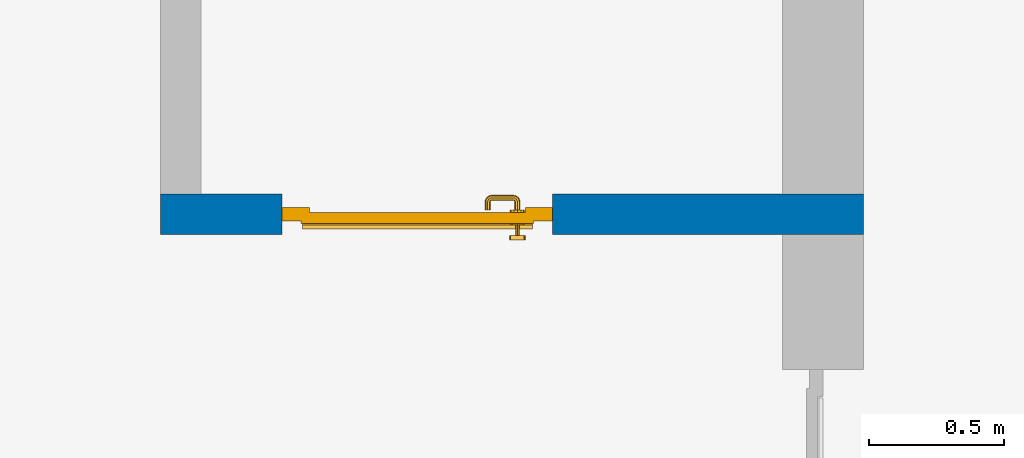
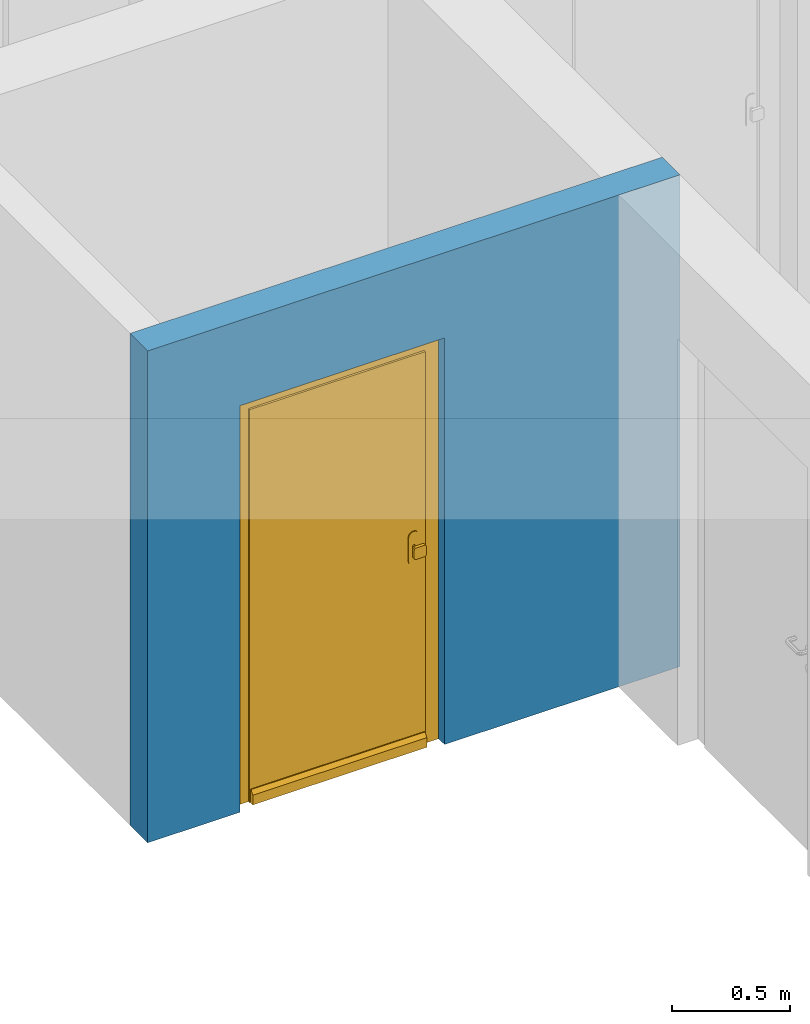
# One storey, part 9 of 48: 1 door, 1 wall, 1 opening.
"""IFC4 building model written with IfcOpenShell, lengths in metres."""

from ifc_helpers import new_model, entity, si_unit, converted_unit, derived_unit, direction, frame, origin_with_axes, place, context, subcontext, project, spatial, polygons, source, transform, mapped, material, type_object, element, fill, save


model = new_model("IFC4")

# Units and contexts
model_context = context("Model", 3, precision=1e-05, world=origin_with_axes(), true_north=direction((0.0, 1.0)))
body_context = subcontext(model_context, "Body", "Model", "MODEL_VIEW")
ifc_project = project(units=[si_unit("LENGTHUNIT", "METRE"), si_unit("AREAUNIT", "SQUARE_METRE"), si_unit("VOLUMEUNIT", "CUBIC_METRE"), converted_unit("PLANEANGLEUNIT", "DEGREE", entity("IfcPlaneAngleMeasure", 0.0174532925199), si_unit("PLANEANGLEUNIT", "RADIAN"), dimensions=[0, 0, 0, 0, 0, 0, 0]), converted_unit("TIMEUNIT", "Year", entity("IfcTimeMeasure", 31556926.0), si_unit("TIMEUNIT", "SECOND"), dimensions=[0, 0, 1, 0, 0, 0, 0]), si_unit("MASSUNIT", "GRAM", prefix="KILO"), si_unit("THERMODYNAMICTEMPERATUREUNIT", "DEGREE_CELSIUS"), si_unit("LUMINOUSINTENSITYUNIT", "LUMEN"), si_unit("ENERGYUNIT", "JOULE", prefix="MEGA"), derived_unit("THERMALCONDUCTANCEUNIT", [(si_unit("POWERUNIT", "WATT"), 1), (si_unit("LENGTHUNIT", "METRE"), -1), (si_unit("THERMODYNAMICTEMPERATUREUNIT", "KELVIN"), -1)]), derived_unit("SPECIFICHEATCAPACITYUNIT", [(si_unit("ENERGYUNIT", "JOULE"), 1), (si_unit("MASSUNIT", "GRAM", prefix="KILO"), -1), (si_unit("THERMODYNAMICTEMPERATUREUNIT", "KELVIN"), -1)]), derived_unit("MASSDENSITYUNIT", [(si_unit("MASSUNIT", "GRAM", prefix="KILO"), 1), (si_unit("VOLUMEUNIT", "CUBIC_METRE"), -1)])], contexts=[model_context])

# Site, building, storey
site_placement = place(None, origin_with_axes())
site = spatial("IfcSite", under=ifc_project, at=site_placement, CompositionType="ELEMENT")
building_placement = place(site_placement, origin_with_axes())
building = spatial("IfcBuilding", under=site, at=building_placement, CompositionType="ELEMENT")
storey_placement = place(building_placement, frame((0.0, 0.0, 3.4), z_axis=(0.0, 0.0, 1.0), x_axis=(1.0, 0.0, 0.0)))
storey = spatial("IfcBuildingStorey", under=building, at=storey_placement, Name="1. Geschoss", CompositionType="ELEMENT", Elevation=3.4)

# Wall, opening, door
ifc_material = material()
wall_type = type_object("IfcWallType", Name="150", PredefinedType="NOTDEFINED")
wall_placement = place(storey_placement, frame((-4.9421993804, -0.428812231043, 0.0), z_axis=(0.0, 0.0, 1.0), x_axis=(-1.0, 0.0, 0.0)))
wall = element("IfcWall", 1, at=wall_placement, inside=storey, type_object=wall_type, material=ifc_material, Name="Wand-002", PredefinedType="NOTDEFINED", context=body_context, shape_type="Tessellation", body=[
    polygons([(2.15, 0.0, 2.1), (2.15, 0.0, 0.0), (2.6, 0.0, 0.0), (2.6, 0.0, 2.54), (0.0, 0.0, 2.54), (0.0, 0.0, 0.0), (1.15, 0.0, 0.0), (1.15, 0.0, 2.1), (2.15, 0.1, 2.1), (2.15, 0.1, 0.0), (2.15, 0.15, 0.0), (2.6, 0.15, 0.0), (2.6, 0.15, 2.54), (0.0, 0.15, 2.54), (0.0, 0.15, 0.0), (1.15, 0.1, 0.0), (1.15, 0.15, 0.0), (1.15, 0.1, 2.1), (2.15, 0.15, 2.1), (1.15, 0.15, 2.1)], [[[1, 2, 3, 4, 5, 6, 7, 8]], [[2, 1, 9, 10]], [[2, 10, 11, 12, 3]], [[4, 3, 12, 13]], [[5, 4, 13, 14]], [[14, 15, 6, 5]], [[16, 7, 6, 15, 17]], [[8, 7, 16, 18]], [[1, 8, 18, 9]], [[10, 9, 19, 11]], [[12, 11, 19, 20, 17, 15, 14, 13]], [[18, 16, 17, 20]], [[9, 18, 20, 19]]], closed=True),
])
opening_placement = place(wall_placement, frame((1.65, 0.0, 0.0), z_axis=(0.0, 0.0, 1.0), x_axis=(1.0, 0.0, 0.0)))
opening = element("IfcOpeningElement", 2, at=opening_placement, cuts=wall, context=body_context, identifier="Reference", shape_type="Tessellation", body=[
    polygons([(-0.5, 0.1, 0.0), (-0.5, 0.1, 2.1), (-0.5, 0.151, 2.1), (-0.5, 0.151, 0.0), (-0.5, -0.001, 0.0), (-0.5, -0.001, 2.1), (0.5, 0.1, 2.1), (0.5, 0.151, 2.1), (0.5, -0.001, 2.1), (0.5, 0.151, 0.0), (0.5, 0.1, 0.0), (0.5, -0.001, 0.0)], [[[1, 2, 3, 4]], [[2, 1, 5, 6]], [[7, 8, 3, 2, 6, 9]], [[8, 10, 4, 3]], [[1, 4, 10, 11, 12, 5]], [[6, 5, 12, 9]], [[7, 11, 10, 8]], [[11, 7, 9, 12]]], closed=True),
])
door_type = type_object("IfcDoorType", Name="Eingang 01 1-Fl 26", OperationType="SINGLE_SWING_RIGHT", PredefinedType="DOOR")
shared_shape = source(origin_with_axes(), body_context, "Body", "Tessellation", [
    polygons([(0.5, -0.05, 0.0), (0.5, -0.03, 0.0), (0.5, -0.03, 2.1), (0.5, -0.05, 2.1), (0.4, -0.05, 0.0), (0.4, -0.03, 0.0), (0.4, -0.03, 2.0), (0.1301, -0.03, 2.0), (0.0001, -0.03, 2.0), (-0.4, -0.03, 2.0), (-0.4, -0.03, 0.0), (-0.5, -0.03, 0.0), (-0.5, -0.03, 2.1), (-0.5, -0.05, 2.1), (-0.5, -0.05, 0.0), (-0.4, -0.05, 0.0), (-0.4, -0.05, 2.0), (0.0001, -0.05, 2.0), (0.1301, -0.05, 2.0), (0.4, -0.05, 2.0)], [[[1, 2, 3, 4]], [[5, 6, 2, 1]], [[2, 6, 7, 8, 9, 10, 11, 12, 13, 3]], [[4, 3, 13, 14]], [[1, 4, 14, 15, 16, 17, 18, 19, 20, 5]], [[20, 7, 6, 5]], [[19, 8, 7, 20]], [[18, 9, 8, 19]], [[17, 10, 9, 18]], [[16, 11, 10, 17]], [[15, 12, 11, 16]], [[14, 13, 12, 15]]], closed=True),
    polygons([(0.5, -0.03, 0.0), (0.5, 0.0, 0.0), (0.5, 0.0, 2.1), (0.5, -0.03, 2.1), (0.43, -0.03, 0.0), (0.43, 0.0, 0.0), (0.43, 0.0, 2.03), (0.1001, 0.0, 2.03), (0.0301, 0.0, 2.03), (-0.43, 0.0, 2.03), (-0.43, 0.0, 0.0), (-0.5, 0.0, 0.0), (-0.5, 0.0, 2.1), (-0.5, -0.03, 2.1), (-0.5, -0.03, 0.0), (-0.43, -0.03, 0.0), (-0.43, -0.03, 2.03), (0.0301, -0.03, 2.03), (0.1001, -0.03, 2.03), (0.43, -0.03, 2.03)], [[[1, 2, 3, 4]], [[5, 6, 2, 1]], [[2, 6, 7, 8, 9, 10, 11, 12, 13, 3]], [[4, 3, 13, 14]], [[1, 4, 14, 15, 16, 17, 18, 19, 20, 5]], [[20, 7, 6, 5]], [[19, 8, 7, 20]], [[18, 9, 8, 19]], [[17, 10, 9, 18]], [[16, 11, 10, 17]], [[15, 12, 11, 16]], [[14, 13, 12, 15]]], closed=True),
    polygons([(0.43, 0.01, 0.0), (-0.43, 0.01, 0.0), (-0.43, 0.01, 2.03), (0.43, 0.01, 2.03), (0.43, -0.03, 0.0), (-0.43, -0.03, 0.0), (-0.43, -0.03, 2.03), (0.43, -0.03, 2.03)], [[[1, 2, 3, 4]], [[2, 1, 5, 6]], [[3, 2, 6, 7]], [[4, 3, 7, 8]], [[1, 4, 8, 5]], [[6, 5, 8, 7]]], closed=True),
    polygons([(0.425, 0.03, 0.0), (-0.425, 0.03, 0.0), (-0.425, 0.03, 0.05), (0.425, 0.03, 0.05), (0.425, 0.01, 0.0), (-0.425, 0.01, 0.0), (-0.425, 0.01, 0.07), (-0.425, 0.015, 0.07), (0.425, 0.015, 0.07), (0.425, 0.01, 0.07)], [[[1, 2, 3, 4]], [[5, 6, 2, 1]], [[2, 6, 7, 8, 3]], [[4, 3, 8, 9]], [[1, 4, 9, 10, 5]], [[10, 7, 6, 5]], [[9, 8, 7, 10]]], closed=True),
    polygons([(-0.3835, -0.04, 1.0733826859), (-0.37, -0.04, 1.077), (-0.37, -0.0399, 1.077), (-0.3835, -0.0399, 1.0733826859), (-0.393382685902, -0.04, 1.0635), (-0.397, -0.04, 1.05), (-0.393382685902, -0.04, 1.0365), (-0.3835, -0.04, 1.0266173141), (-0.37, -0.04, 1.023), (-0.3565, -0.04, 1.0266173141), (-0.346617314098, -0.04, 1.0365), (-0.343, -0.04, 1.05), (-0.346617314098, -0.04, 1.0635), (-0.3565, -0.04, 1.0733826859), (-0.3565, -0.0399, 1.0733826859), (-0.37, -0.0301, 1.077), (-0.3835, -0.0301, 1.0733826859), (-0.393382685902, -0.0399, 1.0635), (-0.397, -0.0399, 1.05), (-0.393382685902, -0.0399, 1.0365), (-0.3835, -0.0399, 1.0266173141), (-0.37, -0.0399, 1.023), (-0.3565, -0.0399, 1.0266173141), (-0.346617314098, -0.0399, 1.0365), (-0.343, -0.0399, 1.05), (-0.346617314098, -0.0399, 1.0635), (-0.3565, -0.0301, 1.0733826859), (-0.37, -0.03, 1.077), (-0.3835, -0.03, 1.0733826859), (-0.393382685902, -0.0301, 1.0635), (-0.397, -0.0301, 1.05), (-0.393382685902, -0.0301, 1.0365), (-0.3835, -0.0301, 1.0266173141), (-0.37, -0.0301, 1.023), (-0.3565, -0.0301, 1.0266173141), (-0.346617314098, -0.0301, 1.0365), (-0.343, -0.0301, 1.05), (-0.346617314098, -0.0301, 1.0635), (-0.3565, -0.03, 1.0733826859), (-0.346617314098, -0.03, 1.0635), (-0.343, -0.03, 1.05), (-0.346617314098, -0.03, 1.0365), (-0.3565, -0.03, 1.0266173141), (-0.37, -0.03, 1.023), (-0.3835, -0.03, 1.0266173141), (-0.393382685902, -0.03, 1.0365), (-0.397, -0.03, 1.05), (-0.393382685902, -0.03, 1.0635)], [[[1, 2, 3, 4]], [[2, 1, 5, 6, 7, 8, 9, 10, 11, 12, 13, 14]], [[2, 14, 15, 3]], [[4, 3, 16, 17]], [[5, 1, 4, 18]], [[6, 5, 18, 19]], [[7, 6, 19, 20]], [[8, 7, 20, 21]], [[9, 8, 21, 22]], [[10, 9, 22, 23]], [[11, 10, 23, 24]], [[12, 11, 24, 25]], [[13, 12, 25, 26]], [[14, 13, 26, 15]], [[3, 15, 27, 16]], [[17, 16, 28, 29]], [[18, 4, 17, 30]], [[19, 18, 30, 31]], [[20, 19, 31, 32]], [[21, 20, 32, 33]], [[22, 21, 33, 34]], [[23, 22, 34, 35]], [[24, 23, 35, 36]], [[25, 24, 36, 37]], [[26, 25, 37, 38]], [[15, 26, 38, 27]], [[16, 27, 39, 28]], [[28, 39, 40, 41, 42, 43, 44, 45, 46, 47, 48, 29]], [[30, 17, 29, 48]], [[31, 30, 48, 47]], [[32, 31, 47, 46]], [[33, 32, 46, 45]], [[34, 33, 45, 44]], [[35, 34, 44, 43]], [[36, 35, 43, 42]], [[37, 36, 42, 41]], [[38, 37, 41, 40]], [[27, 38, 40, 39]]], closed=True),
    polygons([(-0.362532169224, -0.04, 0.959692280177), (-0.365, -0.04, 0.9544), (-0.365, -0.04, 0.952886751346), (-0.346703916638, -0.04, 0.96345), (-0.35655, -0.04, 0.973296083362), (-0.363279754556, -0.04, 0.961639806549), (-0.362532169224, -0.039, 0.959692280177), (-0.365, -0.039, 0.9544), (-0.365, -0.039, 0.952886751346), (-0.365, -0.039, 0.95), (-0.365, -0.039, 0.947113248654), (-0.365, -0.039, 0.941339745962), (-0.365, -0.039, 0.9375), (-0.365, -0.04, 0.9375), (-0.365, -0.04, 0.941339745962), (-0.365, -0.04, 0.947113248654), (-0.365, -0.04, 0.95), (-0.3431, -0.04, 0.95), (-0.346617314098, -0.04, 0.9635), (-0.3565, -0.04, 0.973382685902), (-0.364624817685, -0.04, 0.965143815798), (-0.37, -0.04, 0.9769), (-0.37, -0.04, 0.967425445323), (-0.364624817685, -0.039, 0.965143815798), (-0.363279754556, -0.039, 0.961639806549), (-0.35705, -0.039, 0.972430057958), (-0.347569942042, -0.039, 0.96295), (-0.3441, -0.039, 0.95), (-0.347569942042, -0.039, 0.93705), (-0.35705, -0.039, 0.927569942042), (-0.37, -0.039, 0.9241), (-0.37, -0.039, 0.9325), (-0.366464466094, -0.039, 0.933964466094), (-0.366464466094, -0.04, 0.933964466094), (-0.35655, -0.04, 0.926703916638), (-0.37, -0.04, 0.9325), (-0.37, -0.04, 0.9231), (-0.346703916638, -0.04, 0.93655), (-0.343, -0.04, 0.95), (-0.346617314098, -0.0399, 0.9635), (-0.3565, -0.0399, 0.973382685902), (-0.37, -0.04, 0.977), (-0.375375182315, -0.04, 0.965143815798), (-0.38345, -0.04, 0.973296083362), (-0.376720245444, -0.04, 0.961639806549), (-0.37, -0.039, 0.967425445323), (-0.37, -0.039, 0.9759), (-0.357, -0.039, 0.972516660498), (-0.347483339502, -0.039, 0.963), (-0.344, -0.039, 0.95), (-0.347483339502, -0.039, 0.937), (-0.357, -0.039, 0.927483339502), (-0.38295, -0.039, 0.927569942042), (-0.375, -0.039, 0.941339745962), (-0.375, -0.039, 0.9375), (-0.373535533906, -0.039, 0.933964466094), (-0.37, -0.039, 0.924), (-0.373535533906, -0.04, 0.933964466094), (-0.375, -0.04, 0.9375), (-0.375, -0.04, 0.941339745962), (-0.38345, -0.04, 0.926703916638), (-0.37, -0.04, 0.923), (-0.3565, -0.04, 0.926617314098), (-0.346617314098, -0.04, 0.9365), (-0.343, -0.0399, 0.95), (-0.346617314098, -0.0301, 0.9635), (-0.3565, -0.0301, 0.973382685902), (-0.37, -0.0399, 0.977), (-0.3835, -0.04, 0.973382685902), (-0.375375182315, -0.039, 0.965143815798), (-0.377467830776, -0.04, 0.959692280177), (-0.393296083362, -0.04, 0.96345), (-0.375, -0.04, 0.952886751346), (-0.375, -0.04, 0.9544), (-0.377467830776, -0.039, 0.959692280177), (-0.376720245444, -0.039, 0.961639806549), (-0.38295, -0.039, 0.972430057958), (-0.37, -0.039, 0.976), (-0.357, -0.0389, 0.972516660498), (-0.347483339502, -0.0389, 0.963), (-0.344, -0.0389, 0.95), (-0.347483339502, -0.0389, 0.937), (-0.357, -0.0389, 0.927483339502), (-0.392430057958, -0.039, 0.93705), (-0.375, -0.039, 0.947113248654), (-0.375, -0.039, 0.9544), (-0.375, -0.04, 0.95), (-0.375, -0.04, 0.947113248654), (-0.375, -0.039, 0.95), (-0.375, -0.039, 0.952886751346), (-0.383, -0.039, 0.927483339502), (-0.37, -0.0389, 0.924), (-0.393296083362, -0.04, 0.93655), (-0.3835, -0.04, 0.926617314098), (-0.37, -0.0399, 0.923), (-0.3565, -0.0399, 0.926617314098), (-0.346617314098, -0.0399, 0.9365), (-0.343, -0.0301, 0.95), (-0.346617314098, -0.03, 0.9635), (-0.3565, -0.03, 0.973382685902), (-0.37, -0.0301, 0.977), (-0.3835, -0.0399, 0.973382685902), (-0.393382685902, -0.04, 0.9635), (-0.3969, -0.04, 0.95), (-0.392430057958, -0.039, 0.96295), (-0.383, -0.039, 0.972516660498), (-0.37, -0.0389, 0.976), (-0.357, -0.0301, 0.972516660498), (-0.347483339502, -0.0301, 0.963), (-0.344, -0.0301, 0.95), (-0.347483339502, -0.0301, 0.937), (-0.357, -0.0301, 0.927483339502), (-0.392516660498, -0.039, 0.937), (-0.3959, -0.039, 0.95), (-0.383, -0.0389, 0.927483339502), (-0.37, -0.0301, 0.924), (-0.393382685902, -0.04, 0.9365), (-0.3835, -0.0399, 0.926617314098), (-0.37, -0.0301, 0.923), (-0.3565, -0.0301, 0.926617314098), (-0.346617314098, -0.0301, 0.9365), (-0.343, -0.03, 0.95), (-0.346703916638, -0.03, 0.96345), (-0.35655, -0.03, 0.973296083362), (-0.37, -0.03, 0.977), (-0.3835, -0.0301, 0.973382685902), (-0.393382685902, -0.0399, 0.9635), (-0.397, -0.04, 0.95), (-0.392516660498, -0.039, 0.963), (-0.383, -0.0389, 0.972516660498), (-0.37, -0.0301, 0.976), (-0.357, -0.03, 0.972516660498), (-0.347483339502, -0.03, 0.963), (-0.344, -0.03, 0.95), (-0.347483339502, -0.03, 0.937), (-0.357, -0.03, 0.927483339502), (-0.392516660498, -0.0389, 0.937), (-0.396, -0.039, 0.95), (-0.383, -0.0301, 0.927483339502), (-0.37, -0.03, 0.924), (-0.393382685902, -0.0399, 0.9365), (-0.3835, -0.0301, 0.926617314098), (-0.37, -0.03, 0.923), (-0.3565, -0.03, 0.926617314098), (-0.346617314098, -0.03, 0.9365), (-0.3431, -0.03, 0.95), (-0.347396736961, -0.03, 0.96305), (-0.35695, -0.03, 0.972603263039), (-0.37, -0.03, 0.9769), (-0.3835, -0.03, 0.973382685902), (-0.393382685902, -0.0301, 0.9635), (-0.397, -0.0399, 0.95), (-0.392516660498, -0.0389, 0.963), (-0.383, -0.0301, 0.972516660498), (-0.37, -0.03, 0.976), (-0.3439, -0.03, 0.95), (-0.347396736961, -0.03, 0.93695), (-0.35695, -0.03, 0.927396736961), (-0.392516660498, -0.0301, 0.937), (-0.396, -0.0389, 0.95), (-0.383, -0.03, 0.927483339502), (-0.37, -0.03, 0.9239), (-0.393382685902, -0.0301, 0.9365), (-0.3835, -0.03, 0.926617314098), (-0.37, -0.03, 0.9231), (-0.35655, -0.03, 0.926703916638), (-0.346703916638, -0.03, 0.93655), (-0.37, -0.03, 0.9761), (-0.38345, -0.03, 0.973296083362), (-0.393382685902, -0.03, 0.9635), (-0.397, -0.0301, 0.95), (-0.392516660498, -0.0301, 0.963), (-0.383, -0.03, 0.972516660498), (-0.392516660498, -0.03, 0.937), (-0.396, -0.0301, 0.95), (-0.38305, -0.03, 0.927396736961), (-0.393382685902, -0.03, 0.9365), (-0.38345, -0.03, 0.926703916638), (-0.38305, -0.03, 0.972603263039), (-0.393296083362, -0.03, 0.96345), (-0.397, -0.03, 0.95), (-0.392516660498, -0.03, 0.963), (-0.392603263039, -0.03, 0.93695), (-0.396, -0.03, 0.95), (-0.393296083362, -0.03, 0.93655), (-0.392603263039, -0.03, 0.96305), (-0.3969, -0.03, 0.95), (-0.3961, -0.03, 0.95)], [[[1, 2, 3, 4, 5, 6]], [[2, 1, 7, 8]], [[2, 8, 9, 10, 11, 12, 13, 14, 15, 16, 17, 3]], [[17, 18, 4, 3]], [[19, 20, 5, 4]], [[21, 6, 5, 22, 23]], [[1, 6, 21, 24, 25, 7]], [[7, 25, 26, 27, 9, 8]], [[9, 27, 28, 10]], [[10, 28, 29, 11]], [[11, 29, 30, 12]], [[31, 32, 33, 13, 12, 30]], [[14, 13, 33, 34]], [[35, 15, 14, 34, 36, 37]], [[15, 35, 38, 16]], [[16, 38, 18, 17]], [[39, 19, 4, 18]], [[40, 41, 20, 19]], [[20, 42, 22, 5]], [[43, 23, 22, 44, 45]], [[21, 23, 46, 24]], [[24, 46, 47, 26, 25]], [[27, 26, 48, 49]], [[28, 27, 49, 50]], [[29, 28, 50, 51]], [[30, 29, 51, 52]], [[53, 54, 55, 56, 32, 31]], [[34, 33, 32, 36]], [[31, 30, 52, 57]], [[37, 36, 58, 59, 60, 61]], [[62, 63, 35, 37]], [[63, 64, 38, 35]], [[64, 39, 18, 38]], [[65, 40, 19, 39]], [[66, 67, 41, 40]], [[41, 68, 42, 20]], [[42, 69, 44, 22]], [[23, 43, 70, 46]], [[71, 45, 44, 72, 73, 74]], [[43, 45, 71, 75, 76, 70]], [[70, 76, 77, 47, 46]], [[26, 47, 78, 48]], [[49, 48, 79, 80]], [[50, 49, 80, 81]], [[51, 50, 81, 82]], [[52, 51, 82, 83]], [[54, 53, 84, 85]], [[86, 74, 73, 87, 88, 60, 59, 55, 54, 85, 89, 90]], [[58, 56, 55, 59]], [[36, 32, 56, 58]], [[53, 31, 57, 91]], [[57, 52, 83, 92]], [[88, 93, 61, 60]], [[94, 62, 37, 61]], [[95, 96, 63, 62]], [[96, 97, 64, 63]], [[97, 65, 39, 64]], [[98, 66, 40, 65]], [[99, 100, 67, 66]], [[67, 101, 68, 41]], [[68, 102, 69, 42]], [[69, 103, 72, 44]], [[73, 72, 104, 87]], [[71, 74, 86, 75]], [[75, 86, 90, 105, 77, 76]], [[47, 77, 106, 78]], [[48, 78, 107, 79]], [[80, 79, 108, 109]], [[81, 80, 109, 110]], [[82, 81, 110, 111]], [[83, 82, 111, 112]], [[84, 53, 91, 113]], [[85, 84, 114, 89]], [[87, 104, 93, 88]], [[89, 114, 105, 90]], [[91, 57, 92, 115]], [[92, 83, 112, 116]], [[117, 94, 61, 93]], [[118, 95, 62, 94]], [[119, 120, 96, 95]], [[120, 121, 97, 96]], [[121, 98, 65, 97]], [[122, 99, 66, 98]], [[123, 124, 100, 99]], [[100, 125, 101, 67]], [[101, 126, 102, 68]], [[102, 127, 103, 69]], [[103, 128, 104, 72]], [[77, 105, 129, 106]], [[78, 106, 130, 107]], [[79, 107, 131, 108]], [[109, 108, 132, 133]], [[110, 109, 133, 134]], [[111, 110, 134, 135]], [[112, 111, 135, 136]], [[113, 91, 115, 137]], [[114, 84, 113, 138]], [[128, 117, 93, 104]], [[105, 114, 138, 129]], [[115, 92, 116, 139]], [[116, 112, 136, 140]], [[141, 118, 94, 117]], [[142, 119, 95, 118]], [[143, 144, 120, 119]], [[144, 145, 121, 120]], [[145, 122, 98, 121]], [[146, 123, 99, 122]], [[147, 148, 124, 123]], [[124, 149, 125, 100]], [[125, 150, 126, 101]], [[126, 151, 127, 102]], [[127, 152, 128, 103]], [[106, 129, 153, 130]], [[107, 130, 154, 131]], [[108, 131, 155, 132]], [[133, 132, 148, 147]], [[134, 133, 147, 156]], [[135, 134, 156, 157]], [[136, 135, 157, 158]], [[137, 115, 139, 159]], [[138, 113, 137, 160]], [[152, 141, 117, 128]], [[129, 138, 160, 153]], [[139, 116, 140, 161]], [[140, 136, 158, 162]], [[163, 142, 118, 141]], [[164, 143, 119, 142]], [[165, 166, 144, 143]], [[166, 167, 145, 144]], [[167, 146, 122, 145]], [[156, 147, 123, 146]], [[148, 168, 149, 124]], [[149, 169, 150, 125]], [[150, 170, 151, 126]], [[151, 171, 152, 127]], [[130, 153, 172, 154]], [[131, 154, 173, 155]], [[132, 155, 168, 148]], [[157, 156, 146, 167]], [[158, 157, 167, 166]], [[159, 139, 161, 174]], [[160, 137, 159, 175]], [[171, 163, 141, 152]], [[153, 160, 175, 172]], [[161, 140, 162, 176]], [[162, 158, 166, 165]], [[177, 164, 142, 163]], [[178, 165, 143, 164]], [[168, 179, 169, 149]], [[169, 180, 170, 150]], [[170, 181, 171, 151]], [[154, 172, 182, 173]], [[155, 173, 179, 168]], [[174, 161, 176, 183]], [[175, 159, 174, 184]], [[181, 177, 163, 171]], [[172, 175, 184, 182]], [[176, 162, 165, 178]], [[185, 178, 164, 177]], [[179, 186, 180, 169]], [[180, 187, 181, 170]], [[173, 182, 186, 179]], [[183, 176, 178, 185]], [[184, 174, 183, 188]], [[187, 185, 177, 181]], [[182, 184, 188, 186]], [[186, 188, 187, 180]], [[188, 183, 185, 187]]], closed=True),
    polygons([(-0.38, -0.04, 1.05), (-0.377071067812, -0.04, 1.04292893219), (-0.377071067812, -0.070696439392, 1.04292893219), (-0.38, -0.0709849140336, 1.05), (-0.37, -0.04, 1.04), (-0.37, -0.07, 1.04), (-0.375518993221, -0.0784992452783, 1.04292893219), (-0.378277987014, -0.0796420579258, 1.05), (-0.377071067812, -0.04, 1.05707106781), (-0.377071067812, -0.070696439392, 1.05707106781), (-0.362928932188, -0.04, 1.04292893219), (-0.362928932188, -0.069303560608, 1.04292893219), (-0.368858192988, -0.0757402514855, 1.04), (-0.370704557509, -0.0857045575088, 1.04292893219), (-0.372816199938, -0.0878161999379, 1.05), (-0.375518993221, -0.0784992452783, 1.05707106781), (-0.37, -0.04, 1.06), (-0.37, -0.07, 1.06), (-0.36, -0.04, 1.05), (-0.36, -0.0690150859664, 1.05), (-0.362197392755, -0.0729812576926, 1.04292893219), (-0.365606601718, -0.0806066017178, 1.04), (-0.363499245278, -0.0905189932208, 1.04292893219), (-0.364642057926, -0.0932779870137, 1.05), (-0.370704557509, -0.0857045575088, 1.05707106781), (-0.368858192988, -0.0757402514855, 1.06), (-0.362928932188, -0.04, 1.05707106781), (-0.362928932188, -0.069303560608, 1.05707106781), (-0.359438398962, -0.0718384450452, 1.05), (-0.360508645927, -0.0755086459268, 1.04292893219), (-0.360740251485, -0.0838581929877, 1.04), (-0.355696439392, -0.0920710678119, 1.04292893219), (-0.355984914034, -0.095, 1.05), (-0.363499245278, -0.0905189932208, 1.05707106781), (-0.365606601718, -0.0806066017178, 1.06), (-0.362197392755, -0.0729812576926, 1.05707106781), (-0.358397003498, -0.0733970034977, 1.05), (-0.357981257693, -0.0771973927545, 1.04292893219), (-0.355, -0.085, 1.04), (-0.274303560608, -0.0920710678119, 1.04292893219), (-0.274015085966, -0.095, 1.05), (-0.355696439392, -0.0920710678119, 1.05707106781), (-0.360740251485, -0.0838581929877, 1.06), (-0.360508645927, -0.0755086459268, 1.05707106781), (-0.356838445045, -0.0744383989617, 1.05), (-0.354303560608, -0.0779289321881, 1.04292893219), (-0.275, -0.085, 1.04), (-0.266500754722, -0.0905189932208, 1.04292893219), (-0.265357942074, -0.0932779870137, 1.05), (-0.274303560608, -0.0920710678119, 1.05707106781), (-0.355, -0.085, 1.06), (-0.357981257693, -0.0771973927545, 1.05707106781), (-0.354015085966, -0.075, 1.05), (-0.275696439392, -0.0779289321881, 1.04292893219), (-0.269259748515, -0.0838581929877, 1.04), (-0.259295442491, -0.0857045575088, 1.04292893219), (-0.257183800062, -0.0878161999379, 1.05), (-0.266500754722, -0.0905189932208, 1.05707106781), (-0.275, -0.085, 1.06), (-0.354303560608, -0.0779289321881, 1.05707106781), (-0.275984914034, -0.075, 1.05), (-0.272018742307, -0.0771973927545, 1.04292893219), (-0.264393398282, -0.0806066017178, 1.04), (-0.254481006779, -0.0784992452783, 1.04292893219), (-0.251722012986, -0.0796420579258, 1.05), (-0.259295442491, -0.0857045575088, 1.05707106781), (-0.269259748515, -0.0838581929877, 1.06), (-0.275696439392, -0.0779289321881, 1.05707106781), (-0.273161554955, -0.0744383989617, 1.05), (-0.269491354073, -0.0755086459268, 1.04292893219), (-0.261141807012, -0.0757402514855, 1.04), (-0.252928932188, -0.070696439392, 1.04292893219), (-0.25, -0.0709849140336, 1.05), (-0.254481006779, -0.0784992452783, 1.05707106781), (-0.264393398282, -0.0806066017178, 1.06), (-0.272018742307, -0.0771973927545, 1.05707106781), (-0.271602996502, -0.0733970034977, 1.05), (-0.267802607245, -0.0729812576926, 1.04292893219), (-0.26, -0.07, 1.04), (-0.252928932188, -0.04, 1.04292893219), (-0.25, -0.04, 1.05), (-0.252928932188, -0.070696439392, 1.05707106781), (-0.261141807012, -0.0757402514855, 1.06), (-0.269491354073, -0.0755086459268, 1.05707106781), (-0.270561601038, -0.0718384450452, 1.05), (-0.267071067812, -0.069303560608, 1.04292893219), (-0.26, -0.04, 1.04), (-0.267071067812, -0.04, 1.04292893219), (-0.27, -0.04, 1.05), (-0.267071067812, -0.04, 1.05707106781), (-0.26, -0.04, 1.06), (-0.252928932188, -0.04, 1.05707106781), (-0.26, -0.07, 1.06), (-0.267802607245, -0.0729812576926, 1.05707106781), (-0.27, -0.0690150859664, 1.05), (-0.267071067812, -0.069303560608, 1.05707106781)], [[[1, 2, 3, 4]], [[2, 5, 6, 3]], [[4, 3, 7, 8]], [[9, 1, 4, 10]], [[5, 11, 12, 6]], [[3, 6, 13, 7]], [[8, 7, 14, 15]], [[10, 4, 8, 16]], [[17, 9, 10, 18]], [[11, 19, 20, 12]], [[6, 12, 21, 13]], [[7, 13, 22, 14]], [[15, 14, 23, 24]], [[16, 8, 15, 25]], [[18, 10, 16, 26]], [[27, 17, 18, 28]], [[19, 27, 28, 20]], [[12, 20, 29, 21]], [[13, 21, 30, 22]], [[14, 22, 31, 23]], [[24, 23, 32, 33]], [[25, 15, 24, 34]], [[26, 16, 25, 35]], [[28, 18, 26, 36]], [[20, 28, 36, 29]], [[21, 29, 37, 30]], [[22, 30, 38, 31]], [[23, 31, 39, 32]], [[33, 32, 40, 41]], [[34, 24, 33, 42]], [[35, 25, 34, 43]], [[36, 26, 35, 44]], [[29, 36, 44, 37]], [[30, 37, 45, 38]], [[31, 38, 46, 39]], [[32, 39, 47, 40]], [[41, 40, 48, 49]], [[42, 33, 41, 50]], [[43, 34, 42, 51]], [[44, 35, 43, 52]], [[37, 44, 52, 45]], [[38, 45, 53, 46]], [[39, 46, 54, 47]], [[40, 47, 55, 48]], [[49, 48, 56, 57]], [[50, 41, 49, 58]], [[51, 42, 50, 59]], [[52, 43, 51, 60]], [[45, 52, 60, 53]], [[46, 53, 61, 54]], [[47, 54, 62, 55]], [[48, 55, 63, 56]], [[57, 56, 64, 65]], [[58, 49, 57, 66]], [[59, 50, 58, 67]], [[60, 51, 59, 68]], [[53, 60, 68, 61]], [[54, 61, 69, 62]], [[55, 62, 70, 63]], [[56, 63, 71, 64]], [[65, 64, 72, 73]], [[66, 57, 65, 74]], [[67, 58, 66, 75]], [[68, 59, 67, 76]], [[61, 68, 76, 69]], [[62, 69, 77, 70]], [[63, 70, 78, 71]], [[64, 71, 79, 72]], [[73, 72, 80, 81]], [[74, 65, 73, 82]], [[75, 66, 74, 83]], [[76, 67, 75, 84]], [[69, 76, 84, 77]], [[70, 77, 85, 78]], [[71, 78, 86, 79]], [[72, 79, 87, 80]], [[81, 80, 87, 88, 89, 90, 91, 92]], [[82, 73, 81, 92]], [[83, 74, 82, 93]], [[84, 75, 83, 94]], [[77, 84, 94, 85]], [[78, 85, 95, 86]], [[79, 86, 88, 87]], [[86, 95, 89, 88]], [[95, 96, 90, 89]], [[96, 93, 91, 90]], [[93, 82, 92, 91]], [[94, 83, 93, 96]], [[85, 94, 96, 95]]], closed=False),
    polygons([(-0.364696699141, 0.015, 1.04469669914), (-0.3625, 0.015, 1.05), (-0.364696699141, 0.015, 1.05530330086), (-0.37, 0.015, 1.0575), (-0.375303300859, 0.015, 1.05530330086), (-0.3775, 0.015, 1.05), (-0.375303300859, 0.015, 1.04469669914), (-0.37, 0.015, 1.0425), (-0.364696699141, 0.055, 1.04469669914), (-0.3625, 0.055, 1.05), (-0.364696699141, 0.055, 1.05530330086), (-0.37, 0.055, 1.0575), (-0.375303300859, 0.055, 1.05530330086), (-0.3775, 0.055, 1.05), (-0.375303300859, 0.055, 1.04469669914), (-0.37, 0.055, 1.0425)], [[[1, 2, 3, 4, 5, 6, 7, 8]], [[1, 9, 10, 2]], [[2, 10, 11, 3]], [[3, 11, 12, 4]], [[4, 12, 13, 5]], [[5, 13, 14, 6]], [[6, 14, 15, 7]], [[7, 15, 16, 8]], [[8, 16, 9, 1]], [[9, 16, 15, 14, 13, 12, 11, 10]]], closed=True),
    polygons([(-0.395, 0.01, 0.975), (-0.395, 0.015, 0.975), (-0.393096988313, 0.015, 0.965432914191), (-0.393096988313, 0.01, 0.965432914191), (-0.395, 0.01, 1.1), (-0.395, 0.015, 1.1), (-0.393096988313, 0.015, 1.10956708581), (-0.38767766953, 0.015, 1.11767766953), (-0.379567085809, 0.015, 1.12309698831), (-0.37, 0.015, 1.125), (-0.360432914191, 0.015, 1.12309698831), (-0.35232233047, 0.015, 1.11767766953), (-0.346903011687, 0.015, 1.10956708581), (-0.345, 0.015, 1.1), (-0.345, 0.015, 0.975), (-0.346903011687, 0.015, 0.965432914191), (-0.35232233047, 0.015, 0.95732233047), (-0.360432914191, 0.015, 0.951903011687), (-0.37, 0.015, 0.95), (-0.379567085809, 0.015, 0.951903011687), (-0.38767766953, 0.015, 0.95732233047), (-0.38767766953, 0.01, 0.95732233047), (-0.379567085809, 0.01, 0.951903011687), (-0.37, 0.01, 0.95), (-0.360432914191, 0.01, 0.951903011687), (-0.35232233047, 0.01, 0.95732233047), (-0.346903011687, 0.01, 0.965432914191), (-0.345, 0.01, 0.975), (-0.345, 0.01, 1.1), (-0.346903011687, 0.01, 1.10956708581), (-0.35232233047, 0.01, 1.11767766953), (-0.360432914191, 0.01, 1.12309698831), (-0.37, 0.01, 1.125), (-0.379567085809, 0.01, 1.12309698831), (-0.38767766953, 0.01, 1.11767766953), (-0.393096988313, 0.01, 1.10956708581)], [[[1, 2, 3, 4]], [[5, 6, 2, 1]], [[2, 6, 7, 8, 9, 10, 11, 12, 13, 14, 15, 16, 17, 18, 19, 20, 21, 3]], [[4, 3, 21, 22]], [[1, 4, 22, 23, 24, 25, 26, 27, 28, 29, 30, 31, 32, 33, 34, 35, 36, 5]], [[36, 7, 6, 5]], [[35, 8, 7, 36]], [[34, 9, 8, 35]], [[33, 10, 9, 34]], [[32, 11, 10, 33]], [[31, 12, 11, 32]], [[30, 13, 12, 31]], [[29, 14, 13, 30]], [[28, 15, 14, 29]], [[27, 16, 15, 28]], [[26, 17, 16, 27]], [[25, 18, 17, 26]], [[24, 19, 18, 25]], [[23, 20, 19, 24]], [[22, 21, 20, 23]]], closed=True),
    polygons([(-0.39, 0.055, 1.08), (-0.39, 0.07, 1.08), (-0.395, 0.07, 1.07866025404), (-0.395, 0.055, 1.07866025404), (-0.35, 0.055, 1.08), (-0.35, 0.07, 1.08), (-0.345, 0.07, 1.07866025404), (-0.341339745962, 0.07, 1.075), (-0.34, 0.07, 1.07), (-0.34, 0.07, 1.03), (-0.341339745962, 0.07, 1.025), (-0.345, 0.07, 1.02133974596), (-0.35, 0.07, 1.02), (-0.39, 0.07, 1.02), (-0.395, 0.07, 1.02133974596), (-0.398660254038, 0.07, 1.025), (-0.4, 0.07, 1.03), (-0.4, 0.07, 1.07), (-0.398660254038, 0.07, 1.075), (-0.398660254038, 0.055, 1.075), (-0.4, 0.055, 1.07), (-0.4, 0.055, 1.03), (-0.398660254038, 0.055, 1.025), (-0.395, 0.055, 1.02133974596), (-0.39, 0.055, 1.02), (-0.35, 0.055, 1.02), (-0.345, 0.055, 1.02133974596), (-0.341339745962, 0.055, 1.025), (-0.34, 0.055, 1.03), (-0.34, 0.055, 1.07), (-0.341339745962, 0.055, 1.075), (-0.345, 0.055, 1.07866025404)], [[[1, 2, 3, 4]], [[5, 6, 2, 1]], [[2, 6, 7, 8, 9, 10, 11, 12, 13, 14, 15, 16, 17, 18, 19, 3]], [[4, 3, 19, 20]], [[1, 4, 20, 21, 22, 23, 24, 25, 26, 27, 28, 29, 30, 31, 32, 5]], [[32, 7, 6, 5]], [[31, 8, 7, 32]], [[30, 9, 8, 31]], [[29, 10, 9, 30]], [[28, 11, 10, 29]], [[27, 12, 11, 28]], [[26, 13, 12, 27]], [[25, 14, 13, 26]], [[24, 15, 14, 25]], [[23, 16, 15, 24]], [[22, 17, 16, 23]], [[21, 18, 17, 22]], [[20, 19, 18, 21]]], closed=True),
])
door_placement = place(opening_placement, frame((-0.4, 0.0, 0.0), z_axis=(0.0, 0.0, 1.0), x_axis=(1.0, 0.0, 0.0)))
door = element("IfcDoor", 3, at=door_placement, inside=storey, type_object=door_type, OverallHeight=2.1, OverallWidth=1.0, PredefinedType="DOOR", context=body_context, shape_type="MappedRepresentation", body=[
    mapped(shared_shape, transform((0.4, 0.1, 0.0))),
])
fill(opening, door)

save(model, "model.ifc")
